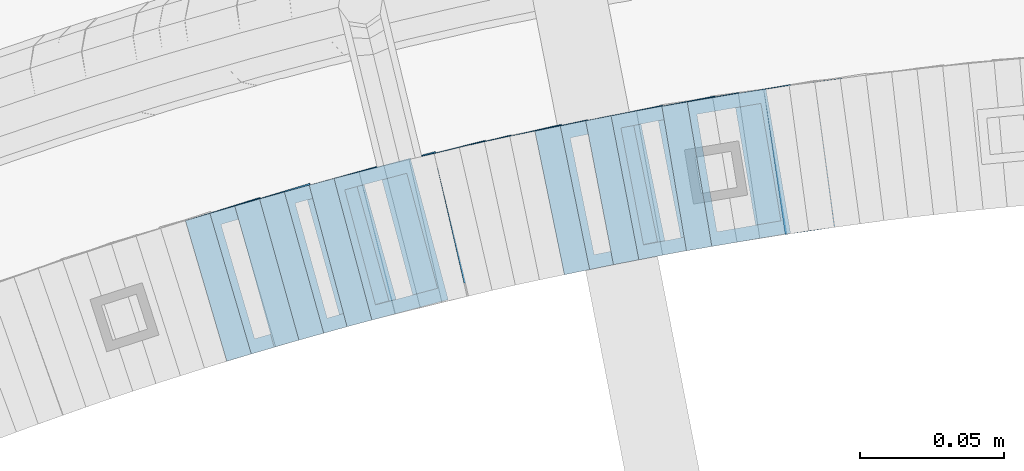
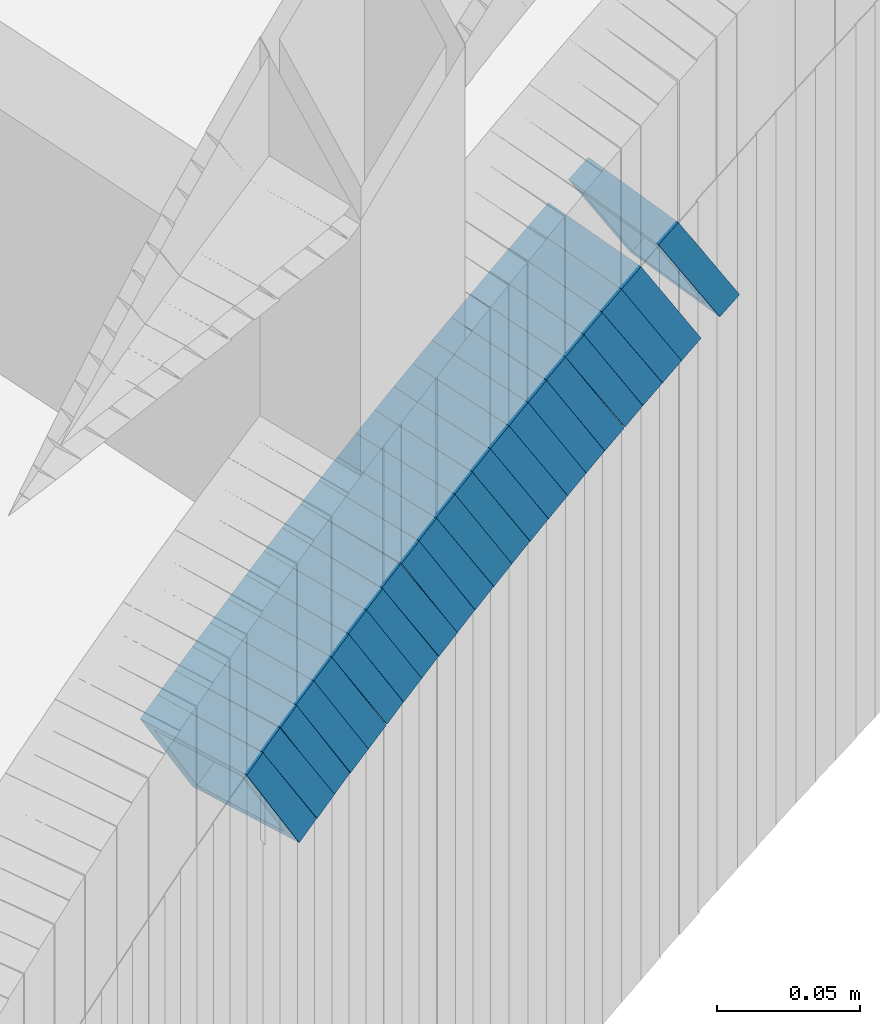
# One storey, part 746 of 975: 23 members.
"""IFC2X3 building model written with IfcOpenShell, lengths in millimetres."""

from ifc_helpers import new_model, si_unit, frame, origin_with_axes, place, context, subcontext, project, spatial, faceted_brep, material, type_object, element, save


model = new_model("IFC2X3")

# Units and contexts
model_context = context("Model", 3, precision=1e-05, world=origin_with_axes())
body_context = subcontext(model_context, "Body", "Model", "MODEL_VIEW")
ifc_project = project(units=[si_unit("LENGTHUNIT", "METRE", prefix="MILLI"), si_unit("AREAUNIT", "SQUARE_METRE"), si_unit("VOLUMEUNIT", "CUBIC_METRE"), si_unit("MASSUNIT", "GRAM", prefix="KILO"), si_unit("TIMEUNIT", "SECOND"), si_unit("PLANEANGLEUNIT", "RADIAN"), si_unit("SOLIDANGLEUNIT", "STERADIAN"), si_unit("THERMODYNAMICTEMPERATUREUNIT", "DEGREE_CELSIUS"), si_unit("LUMINOUSINTENSITYUNIT", "LUMEN")], contexts=[model_context])

# Site, building, storey
site_placement = place(None, origin_with_axes())
site = spatial("IfcSite", under=ifc_project, at=site_placement, CompositionType="ELEMENT")
building_placement = place(site_placement, origin_with_axes())
building = spatial("IfcBuilding", under=site, at=building_placement, Name="Undefined", CompositionType="ELEMENT")
storey_placement = place(building_placement, origin_with_axes())
storey = spatial("IfcBuildingStorey", under=building, at=storey_placement, Name="Undefined", CompositionType="ELEMENT", Elevation=0.0)

# Members
ifc_material = material()
member_type = type_object("IfcMemberType", Name="HSS2X2X.188_TUBES", PredefinedType="NOTDEFINED")
member_1_placement = place(storey_placement, frame((34512.0186384184, 4782.9155873693, 890.591910494647), z_axis=(-0.168030974737274, 0.985781715963956, 2.33967057283735e-10), x_axis=(0.830854457802113, 0.141622918966259, 0.538167091871877)))
element("IfcMember", 1, at=member_1_placement, inside=storey, type_object=member_type, material=ifc_material, Name="WALL", ObjectType="HSS2X2X.188_TUBES", context=body_context, shape_type="Brep", body=[
    faceted_brep([(0.0, 20.6374999999753, -20.6375000000298), (0.0, -20.6375000000153, -20.6375000000153), (10.5948100501191, -20.6375000000335, -20.6375000000844), (10.5948100501555, 20.6374999999971, -20.6375000000116), (0.0, -20.6374999999825, 20.6375000000335), (10.5948100501446, -20.6375000000098, 20.6374999999571), (0.0, 20.6375000000116, 20.6375000000189), (10.5948100501828, 20.6375000000189, 20.6375000000298), (0.0, 25.3999999999724, -25.4000000000342), (0.0, 25.400000000016, 25.4000000000196), (10.5948100501919, 25.4000000000251, 25.4000000000451), (10.5948100501591, 25.3999999999978, -25.4000000000051), (0.0, -25.399999999976, 25.4000000000378), (10.5948100501482, -25.4000000000106, 25.3999999999578), (0.0, -25.400000000016, -25.4000000000196), (10.5948100501118, -25.4000000000378, -25.400000000096)], [[[0, 1, 2, 3]], [[1, 4, 5, 2]], [[4, 6, 7, 5]], [[6, 0, 3, 7]], [[8, 9, 10, 11]], [[9, 12, 13, 10]], [[12, 14, 15, 13]], [[14, 8, 11, 15]], [[13, 15, 11, 10], [5, 7, 3, 2]], [[14, 12, 9, 8], [6, 4, 1, 0]]]),
])
member_2_placement = place(storey_placement, frame((34529.2441156533, 4785.53292837704, 902.113816443157), z_axis=(-0.146141233668583, 0.989263736231054, 2.31722651733435e-10), x_axis=(0.832936057838008, 0.123047371976084, 0.539515400895153)))
element("IfcMember", 2, at=member_2_placement, inside=storey, type_object=member_type, material=ifc_material, Name="WALL", ObjectType="HSS2X2X.188_TUBES", context=body_context, shape_type="Brep", body=[
    faceted_brep([(0.0, 20.6374999999753, -20.6375000000298), (0.0, -20.6375000000153, -20.6375000000153), (10.5744976239494, -20.6375000000207, -20.6375000000335), (10.5744976239657, 20.6375000000098, -20.637500000008), (0.0, -20.6374999999825, 20.6375000000335), (10.5744976239639, -20.6375000000244, 20.6374999999753), (0.0, 20.6375000000116, 20.6375000000189), (10.5744976239803, 20.6374999999989, 20.6374999999935), (0.0, 25.3999999999724, -25.4000000000342), (0.0, 25.400000000016, 25.4000000000196), (10.5744976239857, 25.4000000000051, 25.4000000000015), (10.5744976239675, 25.4000000000124, -25.4000000000051), (0.0, -25.399999999976, 25.4000000000378), (10.5744976239639, -25.4000000000287, 25.3999999999724), (0.0, -25.400000000016, -25.4000000000196), (10.5744976239494, -25.4000000000215, -25.4000000000378)], [[[0, 1, 2, 3]], [[1, 4, 5, 2]], [[4, 6, 7, 5]], [[6, 0, 3, 7]], [[8, 9, 10, 11]], [[9, 12, 13, 10]], [[12, 14, 15, 13]], [[14, 8, 11, 15]], [[13, 15, 11, 10], [5, 7, 3, 2]], [[14, 12, 9, 8], [6, 4, 1, 0]]]),
])
member_3_placement = place(storey_placement, frame((34494.6496643733, 4780.00915007249, 879.079887306541), z_axis=(-0.178885438685502, 0.983869910011631, 2.1800042304676e-10), x_axis=(0.82970883309395, 0.150856152017063, 0.537425040060919)))
element("IfcMember", 3, at=member_3_placement, inside=storey, type_object=member_type, material=ifc_material, Name="WALL", ObjectType="HSS2X2X.188_TUBES", context=body_context, shape_type="Brep", body=[
    faceted_brep([(0.0, 20.6374999999753, -20.6375000000298), (0.0, -20.6375000000153, -20.6375000000153), (10.6061303028146, -20.6374999999571, -20.6374999999643), (10.6061303027491, 20.6374999999971, -20.6375000000007), (0.0, -20.6374999999825, 20.6375000000335), (10.6061303027855, -20.6374999999825, 20.6375000000116), (0.0, 20.6375000000116, 20.6375000000189), (10.6061303027236, 20.637499999968, 20.6374999999716), (0.0, 25.3999999999724, -25.4000000000342), (0.0, 25.400000000016, 25.4000000000196), (10.6061303027163, 25.3999999999651, 25.3999999999651), (10.6061303027454, 25.3999999999942, -25.4000000000051), (0.0, -25.399999999976, 25.4000000000378), (10.6061303027891, -25.3999999999796, 25.4000000000124), (0.0, -25.400000000016, -25.4000000000196), (10.6061303028182, -25.3999999999505, -25.3999999999542)], [[[0, 1, 2, 3]], [[1, 4, 5, 2]], [[4, 6, 7, 5]], [[6, 0, 3, 7]], [[8, 9, 10, 11]], [[9, 12, 13, 10]], [[12, 14, 15, 13]], [[14, 8, 11, 15]], [[13, 15, 11, 10], [5, 7, 3, 2]], [[14, 12, 9, 8], [6, 4, 1, 0]]]),
])
member_4_placement = place(storey_placement, frame((34486.2424009949, 4778.53607922118, 873.375575191873), z_axis=(-0.189674976045004, 0.981846934843883, -4.77562025480438e-11), x_axis=(0.824303982314689, 0.159240542060812, 0.543291261207397)))
element("IfcMember", 4, at=member_4_placement, inside=storey, type_object=member_type, material=ifc_material, Name="WALL", ObjectType="HSS2X2X.188_TUBES", context=body_context, shape_type="Brep", body=[
    faceted_brep([(0.0, 20.6374999999753, -20.6375000000298), (0.0, -20.6375000000153, -20.6375000000153), (10.6831643251735, -20.6375000000498, -20.6375000000953), (10.6831643252044, 20.637499999988, -20.6375000000226), (0.0, -20.6374999999825, 20.6375000000335), (10.6831643251935, -20.6375000000135, 20.637499999968), (0.0, 20.6375000000116, 20.6375000000189), (10.6831643252244, 20.6375000000226, 20.6375000000407), (0.0, 25.3999999999724, -25.4000000000342), (0.0, 25.400000000016, 25.4000000000196), (10.6831643252317, 25.4000000000306, 25.4000000000597), (10.6831643252044, 25.3999999999905, -25.4000000000196), (0.0, -25.399999999976, 25.4000000000378), (10.6831643251917, -25.400000000016, 25.3999999999614), (0.0, -25.400000000016, -25.4000000000196), (10.6831643251644, -25.400000000056, -25.4000000001179)], [[[0, 1, 2, 3]], [[1, 4, 5, 2]], [[4, 6, 7, 5]], [[6, 0, 3, 7]], [[8, 9, 10, 11]], [[9, 12, 13, 10]], [[12, 14, 15, 13]], [[14, 8, 11, 15]], [[13, 15, 11, 10], [5, 7, 3, 2]], [[14, 12, 9, 8], [6, 4, 1, 0]]]),
])
member_5_placement = place(storey_placement, frame((34503.3852983795, 4781.44399531719, 884.900805213881), z_axis=(-0.168030974737274, 0.985781715963956, 2.33967057283735e-10), x_axis=(0.826628220877557, 0.140902537979131, 0.54482314491938)))
element("IfcMember", 5, at=member_5_placement, inside=storey, type_object=member_type, material=ifc_material, Name="WALL", ObjectType="HSS2X2X.188_TUBES", context=body_context, shape_type="Brep", body=[
    faceted_brep([(0.0, 20.6374999999753, -20.6375000000298), (0.0, -20.6375000000153, -20.6375000000153), (10.648004507897, -20.6374999999862, -20.637499999968), (10.6480045078188, 20.6374999999771, -20.6375000000808), (0.0, -20.6374999999825, 20.6375000000335), (10.6480045079406, -20.6374999999698, 20.6375000001062), (0.0, 20.6375000000116, 20.6375000000189), (10.6480045078679, 20.6374999999935, 20.6375000000007), (0.0, 25.3999999999724, -25.4000000000342), (0.0, 25.400000000016, 25.4000000000196), (10.6480045078661, 25.3999999999905, 25.4000000000015), (10.648004507806, 25.3999999999705, -25.4000000000997), (0.0, -25.399999999976, 25.4000000000378), (10.6480045079552, -25.3999999999633, 25.4000000001288), (0.0, -25.400000000016, -25.4000000000196), (10.6480045078988, -25.3999999999814, -25.3999999999651)], [[[0, 1, 2, 3]], [[1, 4, 5, 2]], [[4, 6, 7, 5]], [[6, 0, 3, 7]], [[8, 9, 10, 11]], [[9, 12, 13, 10]], [[12, 14, 15, 13]], [[14, 8, 11, 15]], [[13, 15, 11, 10], [5, 7, 3, 2]], [[14, 12, 9, 8], [6, 4, 1, 0]]]),
])
member_6_placement = place(storey_placement, frame((34468.6990811969, 4775.20009091063, 861.853767835944), z_axis=(-0.200396236142027, 0.979714932283932, -5.21941956321825e-11), x_axis=(0.827212358757651, 0.169202527950373, 0.535808004842972)))
element("IfcMember", 6, at=member_6_placement, inside=storey, type_object=member_type, material=ifc_material, Name="WALL", ObjectType="HSS2X2X.188_TUBES", context=body_context, shape_type="Brep", body=[
    faceted_brep([(0.0, 20.6374999999753, -20.6375000000298), (0.0, -20.6375000000153, -20.6375000000153), (10.6395488625676, -20.6374999999771, -20.6374999999716), (10.6395488625531, 20.6374999999916, -20.6375000000189), (0.0, -20.6374999999825, 20.6375000000335), (10.6395488625731, -20.6374999999844, 20.6375000000153), (0.0, 20.6375000000116, 20.6375000000189), (10.6395488625585, 20.6374999999825, 20.637499999968), (0.0, 25.3999999999724, -25.4000000000342), (0.0, 25.400000000016, 25.4000000000196), (10.6395488625567, 25.3999999999778, 25.3999999999614), (10.6395488625494, 25.3999999999887, -25.4000000000233), (0.0, -25.399999999976, 25.4000000000378), (10.6395488625749, -25.3999999999851, 25.400000000016), (0.0, -25.400000000016, -25.4000000000196), (10.6395488625658, -25.399999999976, -25.3999999999687)], [[[0, 1, 2, 3]], [[1, 4, 5, 2]], [[4, 6, 7, 5]], [[6, 0, 3, 7]], [[8, 9, 10, 11]], [[9, 12, 13, 10]], [[12, 14, 15, 13]], [[14, 8, 11, 15]], [[13, 15, 11, 10], [5, 7, 3, 2]], [[14, 12, 9, 8], [6, 4, 1, 0]]]),
])
member_7_placement = place(storey_placement, frame((34460.0645885689, 4773.43394469126, 856.161909480572), z_axis=(-0.200396236142027, 0.979714932283932, -5.21941956321825e-11), x_axis=(0.823041178253845, 0.168349332052015, 0.542458958167493)))
element("IfcMember", 7, at=member_7_placement, inside=storey, type_object=member_type, material=ifc_material, Name="WALL", ObjectType="HSS2X2X.188_TUBES", context=body_context, shape_type="Brep", body=[
    faceted_brep([(0.0, 20.6374999999753, -20.6375000000298), (0.0, -20.6375000000153, -20.6375000000153), (10.6906501205649, -20.6374999999844, -20.637499999968), (10.690650120574, 20.6375000000098, -20.6374999999716), (0.0, -20.6374999999825, 20.6375000000335), (10.6906501205467, -20.6374999999844, 20.637500000008), (0.0, 20.6375000000116, 20.6375000000189), (10.6906501205558, 20.637500000008, 20.6375000000007), (0.0, 25.3999999999724, -25.4000000000342), (0.0, 25.400000000016, 25.4000000000196), (10.6906501205522, 25.4000000000087, 25.3999999999978), (10.6906501205813, 25.4000000000124, -25.3999999999651), (0.0, -25.399999999976, 25.4000000000378), (10.6906501205431, -25.3999999999833, 25.4000000000051), (0.0, -25.400000000016, -25.4000000000196), (10.6906501205704, -25.3999999999833, -25.3999999999614)], [[[0, 1, 2, 3]], [[1, 4, 5, 2]], [[4, 6, 7, 5]], [[6, 0, 3, 7]], [[8, 9, 10, 11]], [[9, 12, 13, 10]], [[12, 14, 15, 13]], [[14, 8, 11, 15]], [[13, 15, 11, 10], [5, 7, 3, 2]], [[14, 12, 9, 8], [6, 4, 1, 0]]]),
])
member_8_placement = place(storey_placement, frame((34477.2764877839, 4776.80402780543, 867.567168381596), z_axis=(-0.189674976045004, 0.981846934843883, -4.77562025480438e-11), x_axis=(0.828494490235614, 0.160050072045516, 0.536638476152666)))
element("IfcMember", 8, at=member_8_placement, inside=storey, type_object=member_type, material=ifc_material, Name="WALL", ObjectType="HSS2X2X.188_TUBES", context=body_context, shape_type="Brep", body=[
    faceted_brep([(0.0, 20.6374999999753, -20.6375000000298), (0.0, -20.6375000000153, -20.6375000000153), (10.6216759506497, -20.637499999968, -20.6374999999534), (10.6216759506497, 20.6375000000262, -20.6374999999643), (0.0, -20.6374999999825, 20.6375000000335), (10.6216759506169, -20.6374999999935, 20.637500000008), (0.0, 20.6375000000116, 20.6375000000189), (10.6216759506242, 20.6375000000007, 20.6374999999971), (0.0, 25.3999999999724, -25.4000000000342), (0.0, 25.400000000016, 25.4000000000196), (10.6216759506169, 25.3999999999978, 25.3999999999869), (10.6216759506533, 25.4000000000269, -25.3999999999614), (0.0, -25.399999999976, 25.4000000000378), (10.6216759506242, -25.3999999999942, 25.4000000000051), (0.0, -25.400000000016, -25.4000000000196), (10.6216759506569, -25.3999999999614, -25.3999999999432)], [[[0, 1, 2, 3]], [[1, 4, 5, 2]], [[4, 6, 7, 5]], [[6, 0, 3, 7]], [[8, 9, 10, 11]], [[9, 12, 13, 10]], [[12, 14, 15, 13]], [[14, 8, 11, 15]], [[13, 15, 11, 10], [5, 7, 3, 2]], [[14, 12, 9, 8], [6, 4, 1, 0]]]),
])
member_9_placement = place(storey_placement, frame((34451.3532669472, 4771.66327367026, 850.421698847891), z_axis=(-0.202605604136487, 0.979260419486303, -1.52530560626474e-10), x_axis=(0.824209612871699, 0.170526126973393, 0.539999401915723)))
element("IfcMember", 9, at=member_9_placement, inside=storey, type_object=member_type, material=ifc_material, Name="WALL", ObjectType="HSS2X2X.188_TUBES", context=body_context, shape_type="Brep", body=[
    faceted_brep([(0.0, 20.6374999999753, -20.6375000000298), (0.0, -20.6375000000153, -20.6375000000153), (10.5550935571373, -20.6374999999935, -20.6374999999753), (10.5550935571373, 20.6375000000025, -20.6374999999862), (0.0, -20.6374999999825, 20.6375000000335), (10.5550935571027, -20.6374999999989, 20.6374999999862), (0.0, 20.6375000000116, 20.6375000000189), (10.5550935571027, 20.6374999999953, 20.6374999999716), (0.0, 25.3999999999724, -25.4000000000342), (0.0, 25.400000000016, 25.4000000000196), (10.5550935570991, 25.3999999999924, 25.3999999999651), (10.5550935571373, 25.3999999999996, -25.3999999999905), (0.0, -25.399999999976, 25.4000000000378), (10.5550935571009, -25.3999999999996, 25.3999999999833), (0.0, -25.400000000016, -25.4000000000196), (10.5550935571428, -25.3999999999905, -25.3999999999724)], [[[0, 1, 2, 3]], [[1, 4, 5, 2]], [[4, 6, 7, 5]], [[6, 0, 3, 7]], [[8, 9, 10, 11]], [[9, 12, 13, 10]], [[12, 14, 15, 13]], [[14, 8, 11, 15]], [[13, 15, 11, 10], [5, 7, 3, 2]], [[14, 12, 9, 8], [6, 4, 1, 0]]]),
])
member_10_placement = place(storey_placement, frame((34442.7825027597, 4769.93285291531, 844.647562984187), z_axis=(-0.211045983876429, 0.977476134076751, 8.82484982867027e-11), x_axis=(0.821712504265797, 0.177415200057387, 0.541583241175196)))
element("IfcMember", 10, at=member_10_placement, inside=storey, type_object=member_type, material=ifc_material, Name="WALL", ObjectType="HSS2X2X.188_TUBES", context=body_context, shape_type="Brep", body=[
    faceted_brep([(0.0, 20.6374999999753, -20.6375000000298), (0.0, -20.6375000000153, -20.6375000000153), (10.7093417165161, -20.637499999968, -20.6374999999534), (10.709341716436, 20.6374999999898, -20.6375000000116), (0.0, -20.6374999999825, 20.6375000000335), (10.7093417164688, -20.6374999999971, 20.6375000000153), (0.0, 20.6375000000116, 20.6375000000189), (10.7093417163924, 20.6374999999643, 20.6374999999571), (0.0, 25.3999999999724, -25.4000000000342), (0.0, 25.400000000016, 25.4000000000196), (10.7093417163815, 25.3999999999542, 25.3999999999469), (10.7093417164288, 25.3999999999869, -25.4000000000196), (0.0, -25.399999999976, 25.4000000000378), (10.7093417164724, -25.3999999999942, 25.4000000000196), (0.0, -25.400000000016, -25.4000000000196), (10.709341716527, -25.3999999999578, -25.3999999999432)], [[[0, 1, 2, 3]], [[1, 4, 5, 2]], [[4, 6, 7, 5]], [[6, 0, 3, 7]], [[8, 9, 10, 11]], [[9, 12, 13, 10]], [[12, 14, 15, 13]], [[14, 8, 11, 15]], [[13, 15, 11, 10], [5, 7, 3, 2]], [[14, 12, 9, 8], [6, 4, 1, 0]]]),
])
member_11_placement = place(storey_placement, frame((34425.7529407645, 4766.20362708852, 833.200805214004), z_axis=(-0.22404129930948, 0.974579651031007, 9.57256816036534e-11), x_axis=(0.817234718278278, 0.187870050063907, 0.544823145185306)))
element("IfcMember", 11, at=member_11_placement, inside=storey, type_object=member_type, material=ifc_material, Name="WALL", ObjectType="HSS2X2X.188_TUBES", context=body_context, shape_type="Brep", body=[
    faceted_brep([(0.0, 20.6374999999753, -20.6375000000298), (0.0, -20.6375000000153, -20.6375000000153), (10.648004507897, -20.6374999999862, -20.637499999968), (10.6480045078188, 20.6374999999771, -20.6375000000808), (0.0, -20.6374999999825, 20.6375000000335), (10.6480045079406, -20.6374999999698, 20.6375000001062), (0.0, 20.6375000000116, 20.6375000000189), (10.6480045078679, 20.6374999999935, 20.6375000000007), (0.0, 25.3999999999724, -25.4000000000342), (0.0, 25.400000000016, 25.4000000000196), (10.6480045078661, 25.3999999999905, 25.4000000000015), (10.648004507806, 25.3999999999705, -25.4000000000997), (0.0, -25.399999999976, 25.4000000000378), (10.6480045079552, -25.3999999999633, 25.4000000001288), (0.0, -25.400000000016, -25.4000000000196), (10.6480045078988, -25.3999999999814, -25.3999999999651)], [[[0, 1, 2, 3]], [[1, 4, 5, 2]], [[4, 6, 7, 5]], [[6, 0, 3, 7]], [[8, 9, 10, 11]], [[9, 12, 13, 10]], [[12, 14, 15, 13]], [[14, 8, 11, 15]], [[13, 15, 11, 10], [5, 7, 3, 2]], [[14, 12, 9, 8], [6, 4, 1, 0]]]),
])
member_12_placement = place(storey_placement, frame((34434.2881746665, 4768.1657498246, 838.891910494726), z_axis=(-0.22404129930948, 0.974579651031007, 9.57256816036534e-11), x_axis=(0.82141292979664, 0.188830558953227, 0.538167091866747)))
element("IfcMember", 12, at=member_12_placement, inside=storey, type_object=member_type, material=ifc_material, Name="WALL", ObjectType="HSS2X2X.188_TUBES", context=body_context, shape_type="Brep", body=[
    faceted_brep([(0.0, 20.6374999999753, -20.6375000000298), (0.0, -20.6375000000153, -20.6375000000153), (10.5948100501191, -20.6375000000335, -20.6375000000844), (10.5948100501555, 20.6374999999971, -20.6375000000116), (0.0, -20.6374999999825, 20.6375000000335), (10.5948100501446, -20.6375000000098, 20.6374999999571), (0.0, 20.6375000000116, 20.6375000000189), (10.5948100501828, 20.6375000000189, 20.6375000000298), (0.0, 25.3999999999724, -25.4000000000342), (0.0, 25.400000000016, 25.4000000000196), (10.5948100501919, 25.4000000000251, 25.4000000000451), (10.5948100501591, 25.3999999999978, -25.4000000000051), (0.0, -25.399999999976, 25.4000000000378), (10.5948100501482, -25.4000000000106, 25.3999999999578), (0.0, -25.400000000016, -25.4000000000196), (10.5948100501118, -25.4000000000378, -25.400000000096)], [[[0, 1, 2, 3]], [[1, 4, 5, 2]], [[4, 6, 7, 5]], [[6, 0, 3, 7]], [[8, 9, 10, 11]], [[9, 12, 13, 10]], [[12, 14, 15, 13]], [[14, 8, 11, 15]], [[13, 15, 11, 10], [5, 7, 3, 2]], [[14, 12, 9, 8], [6, 4, 1, 0]]]),
])
member_13_placement = place(storey_placement, frame((34417.0990404814, 4764.26822524115, 827.376024415223), z_axis=(-0.23464053321012, 0.972082208547647, 9.88425199466292e-11), x_axis=(0.819915965339659, 0.197910750082063, 0.537186322222644)))
element("IfcMember", 13, at=member_13_placement, inside=storey, type_object=member_type, material=ifc_material, Name="WALL", ObjectType="HSS2X2X.188_TUBES", context=body_context, shape_type="Brep", body=[
    faceted_brep([(0.0, 20.6374999999753, -20.6375000000298), (0.0, -20.6375000000153, -20.6375000000153), (10.6061303028146, -20.6374999999571, -20.6374999999643), (10.6061303027491, 20.6374999999971, -20.6375000000007), (0.0, -20.6374999999825, 20.6375000000335), (10.6061303027855, -20.6374999999825, 20.6375000000116), (0.0, 20.6375000000116, 20.6375000000189), (10.6061303027236, 20.637499999968, 20.6374999999716), (0.0, 25.3999999999724, -25.4000000000342), (0.0, 25.400000000016, 25.4000000000196), (10.6061303027163, 25.3999999999651, 25.3999999999651), (10.6061303027454, 25.3999999999942, -25.4000000000051), (0.0, -25.399999999976, 25.4000000000378), (10.6061303027891, -25.3999999999796, 25.4000000000124), (0.0, -25.400000000016, -25.4000000000196), (10.6061303028182, -25.3999999999505, -25.3999999999542)], [[[0, 1, 2, 3]], [[1, 4, 5, 2]], [[4, 6, 7, 5]], [[6, 0, 3, 7]], [[8, 9, 10, 11]], [[9, 12, 13, 10]], [[12, 14, 15, 13]], [[14, 8, 11, 15]], [[13, 15, 11, 10], [5, 7, 3, 2]], [[14, 12, 9, 8], [6, 4, 1, 0]]]),
])
member_14_placement = place(storey_placement, frame((34408.605505175, 4762.27135278233, 821.659499738966), z_axis=(-0.245156736446225, 0.969483457607729, 1.70881321537309e-10), x_axis=(0.818354737867684, 0.206940278966571, 0.536163448913438)))
element("IfcMember", 14, at=member_14_placement, inside=storey, type_object=member_type, material=ifc_material, Name="WALL", ObjectType="HSS2X2X.188_TUBES", context=body_context, shape_type="Brep", body=[
    faceted_brep([(0.0, 20.6374999999753, -20.6375000000298), (0.0, -20.6375000000153, -20.6375000000153), (10.6348483769107, -20.637499999988, -20.6374999999825), (10.6348483768415, 20.6374999999734, -20.6375000001026), (0.0, -20.6374999999825, 20.6375000000335), (10.6348483769852, -20.6374999999589, 20.6375000001462), (0.0, 20.6375000000116, 20.6375000000189), (10.6348483769161, 20.6375000000044, 20.6375000000226), (0.0, 25.3999999999724, -25.4000000000342), (0.0, 25.400000000016, 25.4000000000196), (10.6348483769179, 25.4000000000015, 25.4000000000233), (10.6348483768288, 25.3999999999669, -25.4000000001324), (0.0, -25.399999999976, 25.4000000000378), (10.6348483769998, -25.3999999999505, 25.4000000001688), (0.0, -25.400000000016, -25.4000000000196), (10.6348483769107, -25.3999999999887, -25.3999999999833)], [[[0, 1, 2, 3]], [[1, 4, 5, 2]], [[4, 6, 7, 5]], [[6, 0, 3, 7]], [[8, 9, 10, 11]], [[9, 12, 13, 10]], [[12, 14, 15, 13]], [[14, 8, 11, 15]], [[13, 15, 11, 10], [5, 7, 3, 2]], [[14, 12, 9, 8], [6, 4, 1, 0]]]),
])
member_15_placement = place(storey_placement, frame((34391.669268159, 4758.15853539335, 810.209101933469), z_axis=(-0.258361740298467, 0.966048244732088, -2.28934482038312e-10), x_axis=(0.813568485883043, 0.217582269968795, 0.539225624922629)))
element("IfcMember", 15, at=member_15_placement, inside=storey, type_object=member_type, material=ifc_material, Name="WALL", ObjectType="HSS2X2X.188_TUBES", context=body_context, shape_type="Brep", body=[
    faceted_brep([(0.0, 20.6374999999753, -20.6375000000298), (0.0, -20.6375000000153, -20.6375000000153), (10.5744976239494, -20.6375000000207, -20.6375000000335), (10.5744976239657, 20.6375000000098, -20.637500000008), (0.0, -20.6374999999825, 20.6375000000335), (10.5744976239639, -20.6375000000244, 20.6374999999753), (0.0, 20.6375000000116, 20.6375000000189), (10.5744976239803, 20.6374999999989, 20.6374999999935), (0.0, 25.3999999999724, -25.4000000000342), (0.0, 25.400000000016, 25.4000000000196), (10.5744976239857, 25.4000000000051, 25.4000000000015), (10.5744976239675, 25.4000000000124, -25.4000000000051), (0.0, -25.399999999976, 25.4000000000378), (10.5744976239639, -25.4000000000287, 25.3999999999724), (0.0, -25.400000000016, -25.4000000000196), (10.5744976239494, -25.4000000000215, -25.4000000000378)], [[[0, 1, 2, 3]], [[1, 4, 5, 2]], [[4, 6, 7, 5]], [[6, 0, 3, 7]], [[8, 9, 10, 11]], [[9, 12, 13, 10]], [[12, 14, 15, 13]], [[14, 8, 11, 15]], [[13, 15, 11, 10], [5, 7, 3, 2]], [[14, 12, 9, 8], [6, 4, 1, 0]]]),
])
member_16_placement = place(storey_placement, frame((34399.8633329435, 4760.00788204232, 815.984606114912), z_axis=(-0.23464053321012, 0.972082208547647, 9.88425199466292e-11), x_axis=(0.815760440437207, 0.196907692105536, 0.543840293291483)))
element("IfcMember", 16, at=member_16_placement, inside=storey, type_object=member_type, material=ifc_material, Name="WALL", ObjectType="HSS2X2X.188_TUBES", context=body_context, shape_type="Brep", body=[
    faceted_brep([(0.0, 20.6374999999753, -20.6375000000298), (0.0, -20.6375000000153, -20.6375000000153), (10.6625512894789, -20.6374999999625, -20.6374999999389), (10.6625512893879, 20.6374999999789, -20.6375000000371), (0.0, -20.6374999999825, 20.6375000000335), (10.6625512894352, -20.6374999999989, 20.6375000000153), (0.0, 20.6375000000116, 20.6375000000189), (10.6625512893443, 20.6374999999443, 20.6374999999134), (0.0, 25.3999999999724, -25.4000000000342), (0.0, 25.400000000016, 25.4000000000196), (10.6625512893297, 25.3999999999342, 25.3999999998996), (10.6625512893916, 25.399999999976, -25.4000000000415), (0.0, -25.399999999976, 25.4000000000378), (10.6625512894389, -25.399999999996, 25.400000000016), (0.0, -25.400000000016, -25.4000000000196), (10.6625512894971, -25.3999999999523, -25.3999999999214)], [[[0, 1, 2, 3]], [[1, 4, 5, 2]], [[4, 6, 7, 5]], [[6, 0, 3, 7]], [[8, 9, 10, 11]], [[9, 12, 13, 10]], [[12, 14, 15, 13]], [[14, 8, 11, 15]], [[13, 15, 11, 10], [5, 7, 3, 2]], [[14, 12, 9, 8], [6, 4, 1, 0]]]),
])
member_17_placement = place(storey_placement, frame((34383.069268159, 4755.85853539334, 804.509101933485), z_axis=(-0.258361740298467, 0.966048244732088, -2.28934482038312e-10), x_axis=(0.813568485883043, 0.217582269968795, 0.539225624922629)))
element("IfcMember", 17, at=member_17_placement, inside=storey, type_object=member_type, material=ifc_material, Name="WALL", ObjectType="HSS2X2X.188_TUBES", context=body_context, shape_type="Brep", body=[
    faceted_brep([(0.0, 20.6374999999753, -20.6375000000298), (0.0, -20.6375000000153, -20.6375000000153), (10.5744976239494, -20.6375000000207, -20.6375000000335), (10.5744976239657, 20.6375000000098, -20.637500000008), (0.0, -20.6374999999825, 20.6375000000335), (10.5744976239639, -20.6375000000244, 20.6374999999753), (0.0, 20.6375000000116, 20.6375000000189), (10.5744976239803, 20.6374999999989, 20.6374999999935), (0.0, 25.3999999999724, -25.4000000000342), (0.0, 25.400000000016, 25.4000000000196), (10.5744976239857, 25.4000000000051, 25.4000000000015), (10.5744976239675, 25.4000000000124, -25.4000000000051), (0.0, -25.399999999976, 25.4000000000378), (10.5744976239639, -25.4000000000287, 25.3999999999724), (0.0, -25.400000000016, -25.4000000000196), (10.5744976239494, -25.4000000000215, -25.4000000000378)], [[[0, 1, 2, 3]], [[1, 4, 5, 2]], [[4, 6, 7, 5]], [[6, 0, 3, 7]], [[8, 9, 10, 11]], [[9, 12, 13, 10]], [[12, 14, 15, 13]], [[14, 8, 11, 15]], [[13, 15, 11, 10], [5, 7, 3, 2]], [[14, 12, 9, 8], [6, 4, 1, 0]]]),
])
member_18_placement = place(storey_placement, frame((34374.8304931141, 4753.7116512837, 798.799615521827), z_axis=(-0.268798967764073, 0.963196301347222, 2.0824586499657e-10), x_axis=(0.807734313542241, 0.22541422687219, 0.544751048691105)))
element("IfcMember", 18, at=member_18_placement, inside=storey, type_object=member_type, material=ifc_material, Name="WALL", ObjectType="HSS2X2X.188_TUBES", context=body_context, shape_type="Brep", body=[
    faceted_brep([(0.0, 20.6374999999753, -20.6375000000298), (0.0, -20.6375000000153, -20.6375000000153), (10.648004507897, -20.6374999999862, -20.637499999968), (10.6480045078188, 20.6374999999771, -20.6375000000808), (0.0, -20.6374999999825, 20.6375000000335), (10.6480045079406, -20.6374999999698, 20.6375000001062), (0.0, 20.6375000000116, 20.6375000000189), (10.6480045078679, 20.6374999999935, 20.6375000000007), (0.0, 25.3999999999724, -25.4000000000342), (0.0, 25.400000000016, 25.4000000000196), (10.6480045078661, 25.3999999999905, 25.4000000000015), (10.648004507806, 25.3999999999705, -25.4000000000997), (0.0, -25.399999999976, 25.4000000000378), (10.6480045079552, -25.3999999999633, 25.4000000001288), (0.0, -25.400000000016, -25.4000000000196), (10.6480045078988, -25.3999999999814, -25.3999999999651)], [[[0, 1, 2, 3]], [[1, 4, 5, 2]], [[4, 6, 7, 5]], [[6, 0, 3, 7]], [[8, 9, 10, 11]], [[9, 12, 13, 10]], [[12, 14, 15, 13]], [[14, 8, 11, 15]], [[13, 15, 11, 10], [5, 7, 3, 2]], [[14, 12, 9, 8], [6, 4, 1, 0]]]),
])
for number, where, z_axis, x_axis, name in (
    (19, (34366.0676552194, 4751.26620815028, 792.990743761369), (-0.268798967764073, 0.963196301347222, 2.0824586499657e-10), (0.811862852083825, 0.226566377023472, 0.538095146055765), "WALL"),
    (20, (34357.4676552193, 4748.86620815026, 787.290743761381), (-0.268798967764073, 0.963196301347222, 2.0824586499657e-10), (0.811862852083825, 0.226566377023472, 0.538095146055765), "WALL"),
):
    element("IfcMember", number, at=place(storey_placement, frame(where, z_axis=z_axis, x_axis=x_axis)), inside=storey, type_object=member_type, material=ifc_material, Name=name, ObjectType="HSS2X2X.188_TUBES", context=body_context, shape_type="Brep", body=[
        faceted_brep([(0.0, 20.6374999999753, -20.6375000000298), (0.0, -20.6375000000153, -20.6375000000153), (10.5948100501191, -20.6375000000335, -20.6375000000844), (10.5948100501555, 20.6374999999971, -20.6375000000116), (0.0, -20.6374999999825, 20.6375000000335), (10.5948100501446, -20.6375000000098, 20.6374999999571), (0.0, 20.6375000000116, 20.6375000000189), (10.5948100501828, 20.6375000000189, 20.6375000000298), (0.0, 25.3999999999724, -25.4000000000342), (0.0, 25.400000000016, 25.4000000000196), (10.5948100501919, 25.4000000000251, 25.4000000000451), (10.5948100501591, 25.3999999999978, -25.4000000000051), (0.0, -25.399999999976, 25.4000000000378), (10.5948100501482, -25.4000000000106, 25.3999999999578), (0.0, -25.400000000016, -25.4000000000196), (10.5948100501118, -25.4000000000378, -25.400000000096)], [[[0, 1, 2, 3]], [[1, 4, 5, 2]], [[4, 6, 7, 5]], [[6, 0, 3, 7]], [[8, 9, 10, 11]], [[9, 12, 13, 10]], [[12, 14, 15, 13]], [[14, 8, 11, 15]], [[13, 15, 11, 10], [5, 7, 3, 2]], [[14, 12, 9, 8], [6, 4, 1, 0]]]),
    ])
member_19_placement = place(storey_placement, frame((34349.2509465312, 4746.68214001513, 781.552242152188), z_axis=(-0.289389501515274, 0.957211427226368, -2.71360931947129e-10), x_axis=(0.808269248899428, 0.244360470969586, 0.535713338933312)))
element("IfcMember", 21, at=member_19_placement, inside=storey, type_object=member_type, material=ifc_material, Name="WALL", ObjectType="HSS2X2X.188_TUBES", context=body_context, shape_type="Brep", body=[
    faceted_brep([(0.0, 20.6374999999753, -20.6375000000298), (0.0, -20.6375000000153, -20.6375000000153), (10.6395488625676, -20.6374999999771, -20.6374999999716), (10.6395488625531, 20.6374999999916, -20.6375000000189), (0.0, -20.6374999999825, 20.6375000000335), (10.6395488625731, -20.6374999999844, 20.6375000000153), (0.0, 20.6375000000116, 20.6375000000189), (10.6395488625585, 20.6374999999825, 20.637499999968), (0.0, 25.3999999999724, -25.4000000000342), (0.0, 25.400000000016, 25.4000000000196), (10.6395488625567, 25.3999999999778, 25.3999999999614), (10.6395488625494, 25.3999999999887, -25.4000000000233), (0.0, -25.399999999976, 25.4000000000378), (10.6395488625749, -25.3999999999851, 25.400000000016), (0.0, -25.400000000016, -25.4000000000196), (10.6395488625658, -25.399999999976, -25.3999999999687)], [[[0, 1, 2, 3]], [[1, 4, 5, 2]], [[4, 6, 7, 5]], [[6, 0, 3, 7]], [[8, 9, 10, 11]], [[9, 12, 13, 10]], [[12, 14, 15, 13]], [[14, 8, 11, 15]], [[13, 15, 11, 10], [5, 7, 3, 2]], [[14, 12, 9, 8], [6, 4, 1, 0]]]),
])
member_20_placement = place(storey_placement, frame((34340.8890310683, 4744.11509357219, 775.948564623233), z_axis=(-0.282166324366815, 0.959365501460898, -3.29950239574828e-10), x_axis=(0.802672991191931, 0.236080292056543, 0.54770627613119)))
element("IfcMember", 22, at=member_20_placement, inside=storey, type_object=member_type, material=ifc_material, Name="WALL", ObjectType="HSS2X2X.188_TUBES", context=body_context, shape_type="Brep", body=[
    faceted_brep([(0.0, 20.6374999999753, -20.6375000000298), (0.0, -20.6375000000153, -20.6375000000153), (10.5948100501191, -20.6375000000335, -20.6375000000844), (10.5948100501555, 20.6374999999971, -20.6375000000116), (0.0, -20.6374999999825, 20.6375000000335), (10.5948100501446, -20.6375000000098, 20.6374999999571), (0.0, 20.6375000000116, 20.6375000000189), (10.5948100501828, 20.6375000000189, 20.6375000000298), (0.0, 25.3999999999724, -25.4000000000342), (0.0, 25.400000000016, 25.4000000000196), (10.5948100501919, 25.4000000000251, 25.4000000000451), (10.5948100501591, 25.3999999999978, -25.4000000000051), (0.0, -25.399999999976, 25.4000000000378), (10.5948100501482, -25.4000000000106, 25.3999999999578), (0.0, -25.400000000016, -25.4000000000196), (10.5948100501118, -25.4000000000378, -25.400000000096)], [[[0, 1, 2, 3]], [[1, 4, 5, 2]], [[4, 6, 7, 5]], [[6, 0, 3, 7]], [[8, 9, 10, 11]], [[9, 12, 13, 10]], [[12, 14, 15, 13]], [[14, 8, 11, 15]], [[13, 15, 11, 10], [5, 7, 3, 2]], [[14, 12, 9, 8], [6, 4, 1, 0]]]),
])
member_21_placement = place(storey_placement, frame((34332.3358878606, 4741.69015405429, 770.032138284785), z_axis=(-0.299538105904627, 0.954084337525289, -3.23771018884145e-11), x_axis=(0.806383883190152, 0.253167033059798, 0.534463737126169)))
element("IfcMember", 23, at=member_21_placement, inside=storey, type_object=member_type, material=ifc_material, Name="WALL", ObjectType="HSS2X2X.188_TUBES", context=body_context, shape_type="Brep", body=[
    faceted_brep([(0.0, 20.6374999999753, -20.6375000000298), (0.0, -20.6375000000153, -20.6375000000153), (10.6625512894789, -20.6374999999625, -20.6374999999389), (10.6625512893879, 20.6374999999789, -20.6375000000371), (0.0, -20.6374999999825, 20.6375000000335), (10.6625512894352, -20.6374999999989, 20.6375000000153), (0.0, 20.6375000000116, 20.6375000000189), (10.6625512893443, 20.6374999999443, 20.6374999999134), (0.0, 25.3999999999724, -25.4000000000342), (0.0, 25.400000000016, 25.4000000000196), (10.6625512893297, 25.3999999999342, 25.3999999998996), (10.6625512893916, 25.399999999976, -25.4000000000415), (0.0, -25.399999999976, 25.4000000000378), (10.6625512894389, -25.399999999996, 25.400000000016), (0.0, -25.400000000016, -25.4000000000196), (10.6625512894971, -25.3999999999523, -25.3999999999214)], [[[0, 1, 2, 3]], [[1, 4, 5, 2]], [[4, 6, 7, 5]], [[6, 0, 3, 7]], [[8, 9, 10, 11]], [[9, 12, 13, 10]], [[12, 14, 15, 13]], [[14, 8, 11, 15]], [[13, 15, 11, 10], [5, 7, 3, 2]], [[14, 12, 9, 8], [6, 4, 1, 0]]]),
])

save(model, "model.ifc")
